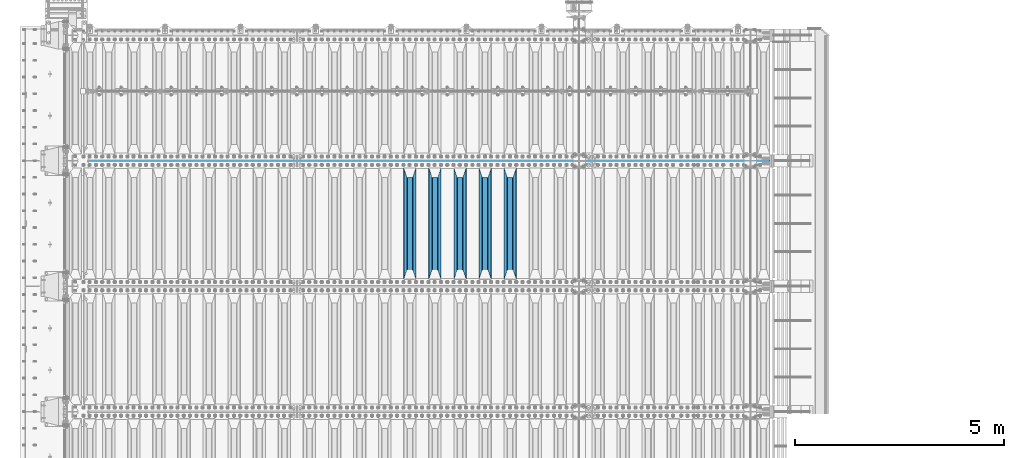
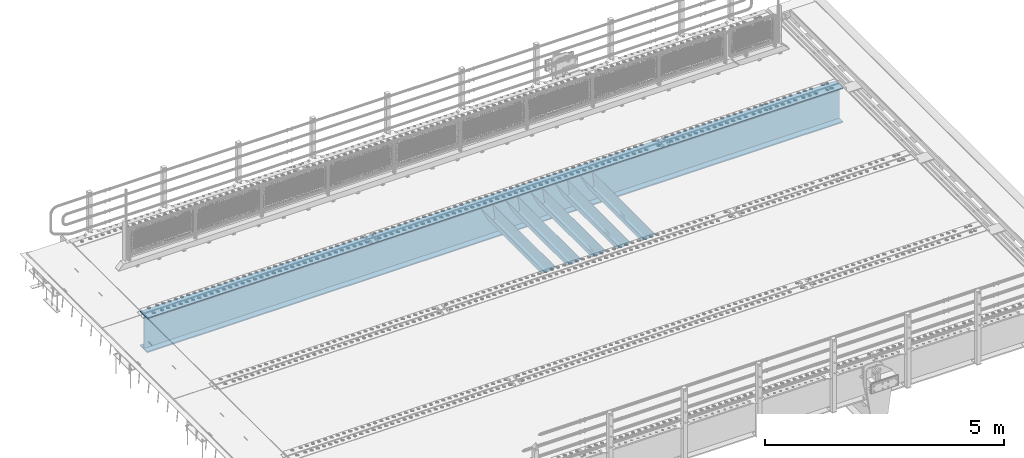
# One storey, part 121 of 257: 6 beams.
"""IFC2X3 building model written with IfcOpenShell, lengths in millimetres."""

from ifc_helpers import new_model, si_unit, frame, origin_with_axes, place, context, subcontext, project, spatial, faceted_brep, material, type_object, element, save


model = new_model("IFC2X3")

# Units and contexts
model_context = context("Model", 3, precision=1e-05, world=origin_with_axes())
body_context = subcontext(model_context, "Body", "Model", "MODEL_VIEW")
ifc_project = project(units=[si_unit("LENGTHUNIT", "METRE", prefix="MILLI"), si_unit("AREAUNIT", "SQUARE_METRE"), si_unit("VOLUMEUNIT", "CUBIC_METRE"), si_unit("MASSUNIT", "GRAM", prefix="KILO"), si_unit("TIMEUNIT", "SECOND"), si_unit("PLANEANGLEUNIT", "RADIAN"), si_unit("SOLIDANGLEUNIT", "STERADIAN"), si_unit("THERMODYNAMICTEMPERATUREUNIT", "DEGREE_CELSIUS"), si_unit("LUMINOUSINTENSITYUNIT", "LUMEN")], contexts=[model_context])

# Site, building, storey
site_placement = place(None, origin_with_axes())
site = spatial("IfcSite", under=ifc_project, at=site_placement, CompositionType="ELEMENT")
building_placement = place(site_placement, origin_with_axes())
building = spatial("IfcBuilding", under=site, at=building_placement, Name="Standard", CompositionType="ELEMENT")
storey_placement = place(building_placement, origin_with_axes())
storey = spatial("IfcBuildingStorey", under=building, at=storey_placement, Name="Undefined", CompositionType="ELEMENT", Elevation=0.0)

# Beams
ifc_material = material(Name="STEEL/S355N")
beam_type_1 = type_object("IfcBeamType", PredefinedType="NOTDEFINED")
beam_1_placement = place(storey_placement, frame((53050.0, 6175.0, -115.0), z_axis=(0.0, 0.0, 1.0), x_axis=(0.0, 1.0, 0.0)))
element("IfcBeam", 1, at=beam_1_placement, inside=storey, type_object=beam_type_1, material=ifc_material, context=body_context, shape_type="Brep", body=[
    faceted_brep([(0.0, 150.0, 115.0), (0.0, 143.690000000002, 115.0), (2650.00000000297, 143.690000000002, 115.0), (2650.00000000297, 150.0, 115.0), (2650.00000000297, 142.059565218406, 110.0000000031), (2650.00000000297, 148.369565218403, 110.0000000031), (2441.90079219208, -80.1103600731149, -98.0992078077845), (2437.7588105432, -77.5672621345584, -102.241189456673), (2434.06523489746, -74.4080125315522, -105.934765102404), (2430.91086095089, -70.7102721255724, -109.089139048974), (2428.37322971128, -66.5649389910031, -111.626770288588), (2426.51472138055, -62.0739139532889, -113.485278619323), (2425.38102192091, -57.3475956567636, -114.618978078955), (2424.99999999987, -52.5021667386536, -115.0), (2424.99999999987, 52.5021667386536, -115.0), (2425.38102192091, 57.3475956567636, -114.618978078955), (2426.51472138055, 62.0739139532889, -113.485278619323), (2428.37322971128, 66.5649389910031, -111.626770288588), (2430.91086095089, 70.7102721255724, -109.089139048974), (2434.06523489746, 74.4080125315522, -105.934765102404), (2437.7588105432, 77.5672621345584, -102.241189456673), (2441.90079219208, 80.1103600731149, -98.0992078077846), (2446.38936140511, 81.9747917625791, -93.6106385947584), (2448.24948500409, 76.2713538057287, -91.7505149957729), (2444.62967112262, 74.76777986261, -95.3703288772456), (2441.28936334126, 72.7168944282894, -98.710636658607), (2438.31067330438, 70.1691124903809, -101.689326695487), (2435.76682334747, 67.1870637758839, -104.233176652398), (2433.72034654133, 63.8440531834931, -106.279653458539), (2432.22154950041, 60.2222587982324, -107.778450499454), (2431.30727574265, 56.4107117849126, -108.692724257221), (2430.99999999987, 52.5031078186876, -109.0), (2430.99999999987, -52.5031078186876, -109.0), (2431.30727574265, -56.4107117849126, -108.692724257221), (2432.22154950041, -60.2222587982324, -107.778450499454), (2433.72034654133, -63.8440531834931, -106.279653458539), (2435.76682334747, -67.1870637758839, -104.233176652398), (2438.31067330438, -70.1691124903809, -101.689326695487), (2441.28936334126, -72.7168944282894, -98.7106366586071), (2444.62967112262, -74.76777986261, -95.3703288772457), (2448.24948500409, -76.2713538057287, -91.7505149957729), (2650.00000000297, -142.059565218406, 110.0000000031), (2650.00000000297, -148.369565218403, 110.0000000031), (2446.38936140511, -81.9747917625791, -93.6106385947584), (2650.00000000297, -143.690000000002, 115.0), (2650.00000000297, -150.0, 115.0), (0.0, -143.690000000002, 115.0), (0.0, -150.0, 115.0), (0.0, -148.369565218258, 110.000000002662), (203.61063859742, -81.9747917625791, -93.6106385947584), (208.099207810447, -80.1103600731149, -98.0992078077845), (212.241189459335, -77.5672621345584, -102.241189456673), (215.934765105066, -74.4080125315522, -105.934765102404), (219.089139051636, -70.7102721255724, -109.089139048974), (221.626770291251, -66.5649389910031, -111.626770288588), (223.485278621985, -62.0739139532889, -113.485278619323), (224.618978081617, -57.3475956567636, -114.618978078955), (225.000000002662, -52.5021667386536, -115.0), (225.000000002662, 52.5021667386536, -115.0), (224.618978081617, 57.3475956567636, -114.618978078955), (223.485278621985, 62.0739139532889, -113.485278619323), (221.626770291251, 66.5649389910031, -111.626770288588), (219.089139051636, 70.7102721255724, -109.089139048974), (215.934765105066, 74.4080125315522, -105.934765102404), (212.241189459335, 77.5672621345584, -102.241189456673), (208.099207810447, 80.1103600731149, -98.0992078077846), (203.61063859742, 81.9747917625791, -93.6106385947584), (0.0, 148.369565218258, 110.000000002662), (0.0, 142.05956521826, 110.000000002662), (201.750514998435, 76.2713538057287, -91.7505149957729), (205.370328879908, 74.76777986261, -95.3703288772456), (208.710636661269, 72.7168944282894, -98.710636658607), (211.689326698149, 70.1691124903809, -101.689326695487), (214.233176655061, 67.1870637758839, -104.233176652398), (216.279653461201, 63.8440531834931, -106.279653458539), (217.778450502116, 60.2222587982324, -107.778450499454), (218.692724259884, 56.4107117849126, -108.692724257221), (219.000000002662, 52.5031078186876, -109.0), (219.000000002662, -52.5031078186876, -109.0), (218.692724259884, -56.4107117849126, -108.692724257221), (217.778450502116, -60.2222587982324, -107.778450499454), (216.279653461201, -63.8440531834931, -106.279653458539), (214.233176655061, -67.1870637758839, -104.233176652398), (211.689326698149, -70.1691124903809, -101.689326695487), (208.710636661269, -72.7168944282894, -98.7106366586071), (205.370328879908, -74.76777986261, -95.3703288772457), (201.750514998435, -76.2713538057287, -91.7505149957729), (0.0, -142.05956521826, 110.000000002662)], [[[0, 1, 2, 3]], [[3, 2, 4, 5]], [[6, 7, 8, 9, 10, 11, 12, 13, 14, 15, 16, 17, 18, 19, 20, 21, 22, 5, 4, 23, 24, 25, 26, 27, 28, 29, 30, 31, 32, 33, 34, 35, 36, 37, 38, 39, 40, 41, 42, 43]], [[44, 45, 42, 41]], [[46, 47, 45, 44]], [[43, 42, 45, 47, 48, 49]], [[6, 43, 49, 50]], [[7, 6, 50, 51]], [[8, 7, 51, 52]], [[9, 8, 52, 53]], [[10, 9, 53, 54]], [[11, 10, 54, 55]], [[12, 11, 55, 56]], [[13, 12, 56, 57]], [[14, 13, 57, 58]], [[15, 14, 58, 59]], [[16, 15, 59, 60]], [[17, 16, 60, 61]], [[18, 17, 61, 62]], [[19, 18, 62, 63]], [[20, 19, 63, 64]], [[21, 20, 64, 65]], [[22, 21, 65, 66]], [[0, 3, 5, 22, 66, 67]], [[1, 0, 67, 68]], [[23, 4, 2, 1, 68, 69]], [[24, 23, 69, 70]], [[25, 24, 70, 71]], [[26, 25, 71, 72]], [[27, 26, 72, 73]], [[28, 27, 73, 74]], [[29, 28, 74, 75]], [[30, 29, 75, 76]], [[31, 30, 76, 77]], [[32, 31, 77, 78]], [[33, 32, 78, 79]], [[34, 33, 79, 80]], [[35, 34, 80, 81]], [[36, 35, 81, 82]], [[37, 36, 82, 83]], [[38, 37, 83, 84]], [[39, 38, 84, 85]], [[40, 39, 85, 86]], [[46, 44, 41, 40, 86, 87]], [[47, 46, 87, 48]], [[86, 85, 84, 83, 82, 81, 80, 79, 78, 77, 76, 75, 74, 73, 72, 71, 70, 69, 68, 67, 66, 65, 64, 63, 62, 61, 60, 59, 58, 57, 56, 55, 54, 53, 52, 51, 50, 49, 48, 87]]]),
])
beam_2_placement = place(storey_placement, frame((52450.0, 6175.0, -115.0), z_axis=(0.0, 0.0, 1.0), x_axis=(0.0, 1.0, 0.0)))
element("IfcBeam", 2, at=beam_2_placement, inside=storey, type_object=beam_type_1, material=ifc_material, context=body_context, shape_type="Brep", body=[
    faceted_brep([(0.0, 150.0, 115.0), (0.0, 143.690000000002, 115.0), (2650.00000000297, 143.690000000002, 115.0), (2650.00000000297, 150.0, 115.0), (2650.00000000297, 142.059565218406, 110.0000000031), (2650.00000000297, 148.369565218403, 110.0000000031), (2441.90079219208, -80.1103600731149, -98.0992078077845), (2437.7588105432, -77.5672621345584, -102.241189456673), (2434.06523489746, -74.4080125315522, -105.934765102404), (2430.91086095089, -70.7102721255724, -109.089139048974), (2428.37322971128, -66.5649389910031, -111.626770288588), (2426.51472138055, -62.0739139532889, -113.485278619323), (2425.38102192091, -57.3475956567636, -114.618978078955), (2424.99999999987, -52.5021667386536, -115.0), (2424.99999999987, 52.5021667386536, -115.0), (2425.38102192091, 57.3475956567636, -114.618978078955), (2426.51472138055, 62.0739139532889, -113.485278619323), (2428.37322971128, 66.5649389910031, -111.626770288588), (2430.91086095089, 70.7102721255724, -109.089139048974), (2434.06523489746, 74.4080125315522, -105.934765102404), (2437.7588105432, 77.5672621345584, -102.241189456673), (2441.90079219208, 80.1103600731149, -98.0992078077846), (2446.38936140511, 81.9747917625791, -93.6106385947584), (2448.24948500409, 76.2713538057287, -91.7505149957729), (2444.62967112262, 74.76777986261, -95.3703288772456), (2441.28936334126, 72.7168944282894, -98.710636658607), (2438.31067330438, 70.1691124903809, -101.689326695487), (2435.76682334747, 67.1870637758839, -104.233176652398), (2433.72034654133, 63.8440531834931, -106.279653458539), (2432.22154950041, 60.2222587982324, -107.778450499454), (2431.30727574265, 56.4107117849126, -108.692724257221), (2430.99999999987, 52.5031078186876, -109.0), (2430.99999999987, -52.5031078186876, -109.0), (2431.30727574265, -56.4107117849126, -108.692724257221), (2432.22154950041, -60.2222587982324, -107.778450499454), (2433.72034654133, -63.8440531834931, -106.279653458539), (2435.76682334747, -67.1870637758839, -104.233176652398), (2438.31067330438, -70.1691124903809, -101.689326695487), (2441.28936334126, -72.7168944282894, -98.7106366586071), (2444.62967112262, -74.76777986261, -95.3703288772457), (2448.24948500409, -76.2713538057287, -91.7505149957729), (2650.00000000297, -142.059565218406, 110.0000000031), (2650.00000000297, -148.369565218403, 110.0000000031), (2446.38936140511, -81.9747917625791, -93.6106385947584), (2650.00000000297, -143.690000000002, 115.0), (2650.00000000297, -150.0, 115.0), (0.0, -143.690000000002, 115.0), (0.0, -150.0, 115.0), (0.0, -148.369565218258, 110.000000002662), (203.61063859742, -81.9747917625791, -93.6106385947584), (208.099207810447, -80.1103600731149, -98.0992078077845), (212.241189459335, -77.5672621345584, -102.241189456673), (215.934765105066, -74.4080125315522, -105.934765102404), (219.089139051636, -70.7102721255724, -109.089139048974), (221.626770291251, -66.5649389910031, -111.626770288588), (223.485278621985, -62.0739139532889, -113.485278619323), (224.618978081617, -57.3475956567636, -114.618978078955), (225.000000002662, -52.5021667386536, -115.0), (225.000000002662, 52.5021667386536, -115.0), (224.618978081617, 57.3475956567636, -114.618978078955), (223.485278621985, 62.0739139532889, -113.485278619323), (221.626770291251, 66.5649389910031, -111.626770288588), (219.089139051636, 70.7102721255724, -109.089139048974), (215.934765105066, 74.4080125315522, -105.934765102404), (212.241189459335, 77.5672621345584, -102.241189456673), (208.099207810447, 80.1103600731149, -98.0992078077846), (203.61063859742, 81.9747917625791, -93.6106385947584), (0.0, 148.369565218258, 110.000000002662), (0.0, 142.05956521826, 110.000000002662), (201.750514998435, 76.2713538057287, -91.7505149957729), (205.370328879908, 74.76777986261, -95.3703288772456), (208.710636661269, 72.7168944282894, -98.710636658607), (211.689326698149, 70.1691124903809, -101.689326695487), (214.233176655061, 67.1870637758839, -104.233176652398), (216.279653461201, 63.8440531834931, -106.279653458539), (217.778450502116, 60.2222587982324, -107.778450499454), (218.692724259884, 56.4107117849126, -108.692724257221), (219.000000002662, 52.5031078186876, -109.0), (219.000000002662, -52.5031078186876, -109.0), (218.692724259884, -56.4107117849126, -108.692724257221), (217.778450502116, -60.2222587982324, -107.778450499454), (216.279653461201, -63.8440531834931, -106.279653458539), (214.233176655061, -67.1870637758839, -104.233176652398), (211.689326698149, -70.1691124903809, -101.689326695487), (208.710636661269, -72.7168944282894, -98.7106366586071), (205.370328879908, -74.76777986261, -95.3703288772457), (201.750514998435, -76.2713538057287, -91.7505149957729), (0.0, -142.05956521826, 110.000000002662)], [[[0, 1, 2, 3]], [[3, 2, 4, 5]], [[6, 7, 8, 9, 10, 11, 12, 13, 14, 15, 16, 17, 18, 19, 20, 21, 22, 5, 4, 23, 24, 25, 26, 27, 28, 29, 30, 31, 32, 33, 34, 35, 36, 37, 38, 39, 40, 41, 42, 43]], [[44, 45, 42, 41]], [[46, 47, 45, 44]], [[43, 42, 45, 47, 48, 49]], [[6, 43, 49, 50]], [[7, 6, 50, 51]], [[8, 7, 51, 52]], [[9, 8, 52, 53]], [[10, 9, 53, 54]], [[11, 10, 54, 55]], [[12, 11, 55, 56]], [[13, 12, 56, 57]], [[14, 13, 57, 58]], [[15, 14, 58, 59]], [[16, 15, 59, 60]], [[17, 16, 60, 61]], [[18, 17, 61, 62]], [[19, 18, 62, 63]], [[20, 19, 63, 64]], [[21, 20, 64, 65]], [[22, 21, 65, 66]], [[0, 3, 5, 22, 66, 67]], [[1, 0, 67, 68]], [[23, 4, 2, 1, 68, 69]], [[24, 23, 69, 70]], [[25, 24, 70, 71]], [[26, 25, 71, 72]], [[27, 26, 72, 73]], [[28, 27, 73, 74]], [[29, 28, 74, 75]], [[30, 29, 75, 76]], [[31, 30, 76, 77]], [[32, 31, 77, 78]], [[33, 32, 78, 79]], [[34, 33, 79, 80]], [[35, 34, 80, 81]], [[36, 35, 81, 82]], [[37, 36, 82, 83]], [[38, 37, 83, 84]], [[39, 38, 84, 85]], [[40, 39, 85, 86]], [[46, 44, 41, 40, 86, 87]], [[47, 46, 87, 48]], [[86, 85, 84, 83, 82, 81, 80, 79, 78, 77, 76, 75, 74, 73, 72, 71, 70, 69, 68, 67, 66, 65, 64, 63, 62, 61, 60, 59, 58, 57, 56, 55, 54, 53, 52, 51, 50, 49, 48, 87]]]),
])
beam_3_placement = place(storey_placement, frame((51850.0, 6175.0, -115.0), z_axis=(0.0, 0.0, 1.0), x_axis=(0.0, 1.0, 0.0)))
element("IfcBeam", 3, at=beam_3_placement, inside=storey, type_object=beam_type_1, material=ifc_material, context=body_context, shape_type="Brep", body=[
    faceted_brep([(0.0, 150.0, 115.0), (0.0, 143.690000000002, 115.0), (2650.00000000297, 143.690000000002, 115.0), (2650.00000000297, 150.0, 115.0), (2650.00000000297, 142.059565218406, 110.0000000031), (2650.00000000297, 148.369565218403, 110.0000000031), (2441.90079219208, -80.1103600731149, -98.0992078077845), (2437.7588105432, -77.5672621345584, -102.241189456673), (2434.06523489746, -74.4080125315522, -105.934765102404), (2430.91086095089, -70.7102721255724, -109.089139048974), (2428.37322971128, -66.5649389910031, -111.626770288588), (2426.51472138055, -62.0739139532889, -113.485278619323), (2425.38102192091, -57.3475956567636, -114.618978078955), (2424.99999999987, -52.5021667386536, -115.0), (2424.99999999987, 52.5021667386536, -115.0), (2425.38102192091, 57.3475956567636, -114.618978078955), (2426.51472138055, 62.0739139532889, -113.485278619323), (2428.37322971128, 66.5649389910031, -111.626770288588), (2430.91086095089, 70.7102721255724, -109.089139048974), (2434.06523489746, 74.4080125315522, -105.934765102404), (2437.7588105432, 77.5672621345584, -102.241189456673), (2441.90079219208, 80.1103600731149, -98.0992078077846), (2446.38936140511, 81.9747917625791, -93.6106385947584), (2448.24948500409, 76.2713538057287, -91.7505149957729), (2444.62967112262, 74.76777986261, -95.3703288772456), (2441.28936334126, 72.7168944282894, -98.710636658607), (2438.31067330438, 70.1691124903809, -101.689326695487), (2435.76682334747, 67.1870637758839, -104.233176652398), (2433.72034654133, 63.8440531834931, -106.279653458539), (2432.22154950041, 60.2222587982324, -107.778450499454), (2431.30727574265, 56.4107117849126, -108.692724257221), (2430.99999999987, 52.5031078186876, -109.0), (2430.99999999987, -52.5031078186876, -109.0), (2431.30727574265, -56.4107117849126, -108.692724257221), (2432.22154950041, -60.2222587982324, -107.778450499454), (2433.72034654133, -63.8440531834931, -106.279653458539), (2435.76682334747, -67.1870637758839, -104.233176652398), (2438.31067330438, -70.1691124903809, -101.689326695487), (2441.28936334126, -72.7168944282894, -98.7106366586071), (2444.62967112262, -74.76777986261, -95.3703288772457), (2448.24948500409, -76.2713538057287, -91.7505149957729), (2650.00000000297, -142.059565218406, 110.0000000031), (2650.00000000297, -148.369565218403, 110.0000000031), (2446.38936140511, -81.9747917625791, -93.6106385947584), (2650.00000000297, -143.690000000002, 115.0), (2650.00000000297, -150.0, 115.0), (0.0, -143.690000000002, 115.0), (0.0, -150.0, 115.0), (0.0, -148.369565218258, 110.000000002662), (203.61063859742, -81.9747917625791, -93.6106385947584), (208.099207810447, -80.1103600731149, -98.0992078077845), (212.241189459335, -77.5672621345584, -102.241189456673), (215.934765105066, -74.4080125315522, -105.934765102404), (219.089139051636, -70.7102721255724, -109.089139048974), (221.626770291251, -66.5649389910031, -111.626770288588), (223.485278621985, -62.0739139532889, -113.485278619323), (224.618978081617, -57.3475956567636, -114.618978078955), (225.000000002662, -52.5021667386536, -115.0), (225.000000002662, 52.5021667386536, -115.0), (224.618978081617, 57.3475956567636, -114.618978078955), (223.485278621985, 62.0739139532889, -113.485278619323), (221.626770291251, 66.5649389910031, -111.626770288588), (219.089139051636, 70.7102721255724, -109.089139048974), (215.934765105066, 74.4080125315522, -105.934765102404), (212.241189459335, 77.5672621345584, -102.241189456673), (208.099207810447, 80.1103600731149, -98.0992078077846), (203.61063859742, 81.9747917625791, -93.6106385947584), (0.0, 148.369565218258, 110.000000002662), (0.0, 142.05956521826, 110.000000002662), (201.750514998435, 76.2713538057287, -91.7505149957729), (205.370328879908, 74.76777986261, -95.3703288772456), (208.710636661269, 72.7168944282894, -98.710636658607), (211.689326698149, 70.1691124903809, -101.689326695487), (214.233176655061, 67.1870637758839, -104.233176652398), (216.279653461201, 63.8440531834931, -106.279653458539), (217.778450502116, 60.2222587982324, -107.778450499454), (218.692724259884, 56.4107117849126, -108.692724257221), (219.000000002662, 52.5031078186876, -109.0), (219.000000002662, -52.5031078186876, -109.0), (218.692724259884, -56.4107117849126, -108.692724257221), (217.778450502116, -60.2222587982324, -107.778450499454), (216.279653461201, -63.8440531834931, -106.279653458539), (214.233176655061, -67.1870637758839, -104.233176652398), (211.689326698149, -70.1691124903809, -101.689326695487), (208.710636661269, -72.7168944282894, -98.7106366586071), (205.370328879908, -74.76777986261, -95.3703288772457), (201.750514998435, -76.2713538057287, -91.7505149957729), (0.0, -142.05956521826, 110.000000002662)], [[[0, 1, 2, 3]], [[3, 2, 4, 5]], [[6, 7, 8, 9, 10, 11, 12, 13, 14, 15, 16, 17, 18, 19, 20, 21, 22, 5, 4, 23, 24, 25, 26, 27, 28, 29, 30, 31, 32, 33, 34, 35, 36, 37, 38, 39, 40, 41, 42, 43]], [[44, 45, 42, 41]], [[46, 47, 45, 44]], [[43, 42, 45, 47, 48, 49]], [[6, 43, 49, 50]], [[7, 6, 50, 51]], [[8, 7, 51, 52]], [[9, 8, 52, 53]], [[10, 9, 53, 54]], [[11, 10, 54, 55]], [[12, 11, 55, 56]], [[13, 12, 56, 57]], [[14, 13, 57, 58]], [[15, 14, 58, 59]], [[16, 15, 59, 60]], [[17, 16, 60, 61]], [[18, 17, 61, 62]], [[19, 18, 62, 63]], [[20, 19, 63, 64]], [[21, 20, 64, 65]], [[22, 21, 65, 66]], [[0, 3, 5, 22, 66, 67]], [[1, 0, 67, 68]], [[23, 4, 2, 1, 68, 69]], [[24, 23, 69, 70]], [[25, 24, 70, 71]], [[26, 25, 71, 72]], [[27, 26, 72, 73]], [[28, 27, 73, 74]], [[29, 28, 74, 75]], [[30, 29, 75, 76]], [[31, 30, 76, 77]], [[32, 31, 77, 78]], [[33, 32, 78, 79]], [[34, 33, 79, 80]], [[35, 34, 80, 81]], [[36, 35, 81, 82]], [[37, 36, 82, 83]], [[38, 37, 83, 84]], [[39, 38, 84, 85]], [[40, 39, 85, 86]], [[46, 44, 41, 40, 86, 87]], [[47, 46, 87, 48]], [[86, 85, 84, 83, 82, 81, 80, 79, 78, 77, 76, 75, 74, 73, 72, 71, 70, 69, 68, 67, 66, 65, 64, 63, 62, 61, 60, 59, 58, 57, 56, 55, 54, 53, 52, 51, 50, 49, 48, 87]]]),
])
beam_4_placement = place(storey_placement, frame((51250.0, 6175.0, -115.0), z_axis=(0.0, 0.0, 1.0), x_axis=(0.0, 1.0, 0.0)))
element("IfcBeam", 4, at=beam_4_placement, inside=storey, type_object=beam_type_1, material=ifc_material, context=body_context, shape_type="Brep", body=[
    faceted_brep([(0.0, 150.0, 115.0), (0.0, 143.690000000002, 115.0), (2650.00000000297, 143.690000000002, 115.0), (2650.00000000297, 150.0, 115.0), (2650.00000000297, 142.059565218406, 110.0000000031), (2650.00000000297, 148.369565218403, 110.0000000031), (2441.90079219208, -80.1103600731149, -98.0992078077845), (2437.7588105432, -77.5672621345584, -102.241189456673), (2434.06523489746, -74.4080125315522, -105.934765102404), (2430.91086095089, -70.7102721255724, -109.089139048974), (2428.37322971128, -66.5649389910031, -111.626770288588), (2426.51472138055, -62.0739139532889, -113.485278619323), (2425.38102192091, -57.3475956567636, -114.618978078955), (2424.99999999987, -52.5021667386536, -115.0), (2424.99999999987, 52.5021667386536, -115.0), (2425.38102192091, 57.3475956567636, -114.618978078955), (2426.51472138055, 62.0739139532889, -113.485278619323), (2428.37322971128, 66.5649389910031, -111.626770288588), (2430.91086095089, 70.7102721255724, -109.089139048974), (2434.06523489746, 74.4080125315522, -105.934765102404), (2437.7588105432, 77.5672621345584, -102.241189456673), (2441.90079219208, 80.1103600731149, -98.0992078077846), (2446.38936140511, 81.9747917625791, -93.6106385947584), (2448.24948500409, 76.2713538057287, -91.7505149957729), (2444.62967112262, 74.76777986261, -95.3703288772456), (2441.28936334126, 72.7168944282894, -98.710636658607), (2438.31067330438, 70.1691124903809, -101.689326695487), (2435.76682334747, 67.1870637758839, -104.233176652398), (2433.72034654133, 63.8440531834931, -106.279653458539), (2432.22154950041, 60.2222587982324, -107.778450499454), (2431.30727574265, 56.4107117849126, -108.692724257221), (2430.99999999987, 52.5031078186876, -109.0), (2430.99999999987, -52.5031078186876, -109.0), (2431.30727574265, -56.4107117849126, -108.692724257221), (2432.22154950041, -60.2222587982324, -107.778450499454), (2433.72034654133, -63.8440531834931, -106.279653458539), (2435.76682334747, -67.1870637758839, -104.233176652398), (2438.31067330438, -70.1691124903809, -101.689326695487), (2441.28936334126, -72.7168944282894, -98.7106366586071), (2444.62967112262, -74.76777986261, -95.3703288772457), (2448.24948500409, -76.2713538057287, -91.7505149957729), (2650.00000000297, -142.059565218406, 110.0000000031), (2650.00000000297, -148.369565218403, 110.0000000031), (2446.38936140511, -81.9747917625791, -93.6106385947584), (2650.00000000297, -143.690000000002, 115.0), (2650.00000000297, -150.0, 115.0), (0.0, -143.690000000002, 115.0), (0.0, -150.0, 115.0), (0.0, -148.369565218258, 110.000000002662), (203.61063859742, -81.9747917625791, -93.6106385947584), (208.099207810447, -80.1103600731149, -98.0992078077845), (212.241189459335, -77.5672621345584, -102.241189456673), (215.934765105066, -74.4080125315522, -105.934765102404), (219.089139051636, -70.7102721255724, -109.089139048974), (221.626770291251, -66.5649389910031, -111.626770288588), (223.485278621985, -62.0739139532889, -113.485278619323), (224.618978081617, -57.3475956567636, -114.618978078955), (225.000000002662, -52.5021667386536, -115.0), (225.000000002662, 52.5021667386536, -115.0), (224.618978081617, 57.3475956567636, -114.618978078955), (223.485278621985, 62.0739139532889, -113.485278619323), (221.626770291251, 66.5649389910031, -111.626770288588), (219.089139051636, 70.7102721255724, -109.089139048974), (215.934765105066, 74.4080125315522, -105.934765102404), (212.241189459335, 77.5672621345584, -102.241189456673), (208.099207810447, 80.1103600731149, -98.0992078077846), (203.61063859742, 81.9747917625791, -93.6106385947584), (0.0, 148.369565218258, 110.000000002662), (0.0, 142.05956521826, 110.000000002662), (201.750514998435, 76.2713538057287, -91.7505149957729), (205.370328879908, 74.76777986261, -95.3703288772456), (208.710636661269, 72.7168944282894, -98.710636658607), (211.689326698149, 70.1691124903809, -101.689326695487), (214.233176655061, 67.1870637758839, -104.233176652398), (216.279653461201, 63.8440531834931, -106.279653458539), (217.778450502116, 60.2222587982324, -107.778450499454), (218.692724259884, 56.4107117849126, -108.692724257221), (219.000000002662, 52.5031078186876, -109.0), (219.000000002662, -52.5031078186876, -109.0), (218.692724259884, -56.4107117849126, -108.692724257221), (217.778450502116, -60.2222587982324, -107.778450499454), (216.279653461201, -63.8440531834931, -106.279653458539), (214.233176655061, -67.1870637758839, -104.233176652398), (211.689326698149, -70.1691124903809, -101.689326695487), (208.710636661269, -72.7168944282894, -98.7106366586071), (205.370328879908, -74.76777986261, -95.3703288772457), (201.750514998435, -76.2713538057287, -91.7505149957729), (0.0, -142.05956521826, 110.000000002662)], [[[0, 1, 2, 3]], [[3, 2, 4, 5]], [[6, 7, 8, 9, 10, 11, 12, 13, 14, 15, 16, 17, 18, 19, 20, 21, 22, 5, 4, 23, 24, 25, 26, 27, 28, 29, 30, 31, 32, 33, 34, 35, 36, 37, 38, 39, 40, 41, 42, 43]], [[44, 45, 42, 41]], [[46, 47, 45, 44]], [[43, 42, 45, 47, 48, 49]], [[6, 43, 49, 50]], [[7, 6, 50, 51]], [[8, 7, 51, 52]], [[9, 8, 52, 53]], [[10, 9, 53, 54]], [[11, 10, 54, 55]], [[12, 11, 55, 56]], [[13, 12, 56, 57]], [[14, 13, 57, 58]], [[15, 14, 58, 59]], [[16, 15, 59, 60]], [[17, 16, 60, 61]], [[18, 17, 61, 62]], [[19, 18, 62, 63]], [[20, 19, 63, 64]], [[21, 20, 64, 65]], [[22, 21, 65, 66]], [[0, 3, 5, 22, 66, 67]], [[1, 0, 67, 68]], [[23, 4, 2, 1, 68, 69]], [[24, 23, 69, 70]], [[25, 24, 70, 71]], [[26, 25, 71, 72]], [[27, 26, 72, 73]], [[28, 27, 73, 74]], [[29, 28, 74, 75]], [[30, 29, 75, 76]], [[31, 30, 76, 77]], [[32, 31, 77, 78]], [[33, 32, 78, 79]], [[34, 33, 79, 80]], [[35, 34, 80, 81]], [[36, 35, 81, 82]], [[37, 36, 82, 83]], [[38, 37, 83, 84]], [[39, 38, 84, 85]], [[40, 39, 85, 86]], [[46, 44, 41, 40, 86, 87]], [[47, 46, 87, 48]], [[86, 85, 84, 83, 82, 81, 80, 79, 78, 77, 76, 75, 74, 73, 72, 71, 70, 69, 68, 67, 66, 65, 64, 63, 62, 61, 60, 59, 58, 57, 56, 55, 54, 53, 52, 51, 50, 49, 48, 87]]]),
])
beam_5_placement = place(storey_placement, frame((50650.0, 6175.0, -115.0), z_axis=(0.0, 0.0, 1.0), x_axis=(0.0, 1.0, 0.0)))
element("IfcBeam", 5, at=beam_5_placement, inside=storey, type_object=beam_type_1, material=ifc_material, context=body_context, shape_type="Brep", body=[
    faceted_brep([(0.0, 150.0, 115.0), (0.0, 143.690000000002, 115.0), (2650.00000000297, 143.690000000002, 115.0), (2650.00000000297, 150.0, 115.0), (2650.00000000297, 142.059565218406, 110.0000000031), (2650.00000000297, 148.369565218403, 110.0000000031), (2441.90079219208, -80.1103600731149, -98.0992078077845), (2437.7588105432, -77.5672621345584, -102.241189456673), (2434.06523489746, -74.4080125315522, -105.934765102404), (2430.91086095089, -70.7102721255724, -109.089139048974), (2428.37322971128, -66.5649389910031, -111.626770288588), (2426.51472138055, -62.0739139532889, -113.485278619323), (2425.38102192091, -57.3475956567636, -114.618978078955), (2424.99999999987, -52.5021667386536, -115.0), (2424.99999999987, 52.5021667386536, -115.0), (2425.38102192091, 57.3475956567636, -114.618978078955), (2426.51472138055, 62.0739139532889, -113.485278619323), (2428.37322971128, 66.5649389910031, -111.626770288588), (2430.91086095089, 70.7102721255724, -109.089139048974), (2434.06523489746, 74.4080125315522, -105.934765102404), (2437.7588105432, 77.5672621345584, -102.241189456673), (2441.90079219208, 80.1103600731149, -98.0992078077846), (2446.38936140511, 81.9747917625791, -93.6106385947584), (2448.24948500409, 76.2713538057287, -91.7505149957729), (2444.62967112262, 74.76777986261, -95.3703288772456), (2441.28936334126, 72.7168944282894, -98.710636658607), (2438.31067330438, 70.1691124903809, -101.689326695487), (2435.76682334747, 67.1870637758839, -104.233176652398), (2433.72034654133, 63.8440531834931, -106.279653458539), (2432.22154950041, 60.2222587982324, -107.778450499454), (2431.30727574265, 56.4107117849126, -108.692724257221), (2430.99999999987, 52.5031078186876, -109.0), (2430.99999999987, -52.5031078186876, -109.0), (2431.30727574265, -56.4107117849126, -108.692724257221), (2432.22154950041, -60.2222587982324, -107.778450499454), (2433.72034654133, -63.8440531834931, -106.279653458539), (2435.76682334747, -67.1870637758839, -104.233176652398), (2438.31067330438, -70.1691124903809, -101.689326695487), (2441.28936334126, -72.7168944282894, -98.7106366586071), (2444.62967112262, -74.76777986261, -95.3703288772457), (2448.24948500409, -76.2713538057287, -91.7505149957729), (2650.00000000297, -142.059565218406, 110.0000000031), (2650.00000000297, -148.369565218403, 110.0000000031), (2446.38936140511, -81.9747917625791, -93.6106385947584), (2650.00000000297, -143.690000000002, 115.0), (2650.00000000297, -150.0, 115.0), (0.0, -143.690000000002, 115.0), (0.0, -150.0, 115.0), (0.0, -148.369565218258, 110.000000002662), (203.61063859742, -81.9747917625791, -93.6106385947584), (208.099207810447, -80.1103600731149, -98.0992078077845), (212.241189459335, -77.5672621345584, -102.241189456673), (215.934765105066, -74.4080125315522, -105.934765102404), (219.089139051636, -70.7102721255724, -109.089139048974), (221.626770291251, -66.5649389910031, -111.626770288588), (223.485278621985, -62.0739139532889, -113.485278619323), (224.618978081617, -57.3475956567636, -114.618978078955), (225.000000002662, -52.5021667386536, -115.0), (225.000000002662, 52.5021667386536, -115.0), (224.618978081617, 57.3475956567636, -114.618978078955), (223.485278621985, 62.0739139532889, -113.485278619323), (221.626770291251, 66.5649389910031, -111.626770288588), (219.089139051636, 70.7102721255724, -109.089139048974), (215.934765105066, 74.4080125315522, -105.934765102404), (212.241189459335, 77.5672621345584, -102.241189456673), (208.099207810447, 80.1103600731149, -98.0992078077846), (203.61063859742, 81.9747917625791, -93.6106385947584), (0.0, 148.369565218258, 110.000000002662), (0.0, 142.05956521826, 110.000000002662), (201.750514998435, 76.2713538057287, -91.7505149957729), (205.370328879908, 74.76777986261, -95.3703288772456), (208.710636661269, 72.7168944282894, -98.710636658607), (211.689326698149, 70.1691124903809, -101.689326695487), (214.233176655061, 67.1870637758839, -104.233176652398), (216.279653461201, 63.8440531834931, -106.279653458539), (217.778450502116, 60.2222587982324, -107.778450499454), (218.692724259884, 56.4107117849126, -108.692724257221), (219.000000002662, 52.5031078186876, -109.0), (219.000000002662, -52.5031078186876, -109.0), (218.692724259884, -56.4107117849126, -108.692724257221), (217.778450502116, -60.2222587982324, -107.778450499454), (216.279653461201, -63.8440531834931, -106.279653458539), (214.233176655061, -67.1870637758839, -104.233176652398), (211.689326698149, -70.1691124903809, -101.689326695487), (208.710636661269, -72.7168944282894, -98.7106366586071), (205.370328879908, -74.76777986261, -95.3703288772457), (201.750514998435, -76.2713538057287, -91.7505149957729), (0.0, -142.05956521826, 110.000000002662)], [[[0, 1, 2, 3]], [[3, 2, 4, 5]], [[6, 7, 8, 9, 10, 11, 12, 13, 14, 15, 16, 17, 18, 19, 20, 21, 22, 5, 4, 23, 24, 25, 26, 27, 28, 29, 30, 31, 32, 33, 34, 35, 36, 37, 38, 39, 40, 41, 42, 43]], [[44, 45, 42, 41]], [[46, 47, 45, 44]], [[43, 42, 45, 47, 48, 49]], [[6, 43, 49, 50]], [[7, 6, 50, 51]], [[8, 7, 51, 52]], [[9, 8, 52, 53]], [[10, 9, 53, 54]], [[11, 10, 54, 55]], [[12, 11, 55, 56]], [[13, 12, 56, 57]], [[14, 13, 57, 58]], [[15, 14, 58, 59]], [[16, 15, 59, 60]], [[17, 16, 60, 61]], [[18, 17, 61, 62]], [[19, 18, 62, 63]], [[20, 19, 63, 64]], [[21, 20, 64, 65]], [[22, 21, 65, 66]], [[0, 3, 5, 22, 66, 67]], [[1, 0, 67, 68]], [[23, 4, 2, 1, 68, 69]], [[24, 23, 69, 70]], [[25, 24, 70, 71]], [[26, 25, 71, 72]], [[27, 26, 72, 73]], [[28, 27, 73, 74]], [[29, 28, 74, 75]], [[30, 29, 75, 76]], [[31, 30, 76, 77]], [[32, 31, 77, 78]], [[33, 32, 78, 79]], [[34, 33, 79, 80]], [[35, 34, 80, 81]], [[36, 35, 81, 82]], [[37, 36, 82, 83]], [[38, 37, 83, 84]], [[39, 38, 84, 85]], [[40, 39, 85, 86]], [[46, 44, 41, 40, 86, 87]], [[47, 46, 87, 48]], [[86, 85, 84, 83, 82, 81, 80, 79, 78, 77, 76, 75, 74, 73, 72, 71, 70, 69, 68, 67, 66, 65, 64, 63, 62, 61, 60, 59, 58, 57, 56, 55, 54, 53, 52, 51, 50, 49, 48, 87]]]),
])
beam_type_2 = type_object("IfcBeamType", Name="HEA900", PredefinedType="NOTDEFINED")
beam_6_placement = place(storey_placement, frame((42460.0, 9000.0, -445.0), z_axis=(0.0, 0.0, 1.0), x_axis=(1.0, 0.0, 0.0)))
element("IfcBeam", 6, at=beam_6_placement, inside=storey, type_object=beam_type_2, material=ifc_material, ObjectType="HEA900", context=body_context, shape_type="Brep", body=[
    faceted_brep([(0.0, 150.0, -445.0), (0.0, 150.0, -415.0), (16807.0, 150.0, -415.0), (16807.0, 150.0, -445.0), (0.0, 8.0, -415.0), (16807.0, 8.0, -415.0), (0.0, 8.0, 415.0), (16807.0, 8.0, 415.0), (0.0, 150.0, 415.0), (16807.0, 150.0, 415.0), (0.0, 150.0, 445.0), (16807.0, 150.0, 445.0), (0.0, -150.0, 445.0), (16807.0, -150.0, 445.0), (0.0, -150.0, 415.0), (16807.0, -150.0, 415.0), (0.0, -8.0, 415.0), (16807.0, -8.0, 415.0), (0.0, -8.0, -415.0), (16807.0, -8.0, -415.0), (0.0, -150.0, -415.0), (16807.0, -150.0, -415.0), (0.0, -150.0, -445.0), (16807.0, -150.0, -445.0)], [[[0, 1, 2, 3]], [[1, 4, 5, 2]], [[4, 6, 7, 5]], [[6, 8, 9, 7]], [[8, 10, 11, 9]], [[10, 12, 13, 11]], [[12, 14, 15, 13]], [[14, 16, 17, 15]], [[16, 18, 19, 17]], [[18, 20, 21, 19]], [[20, 22, 23, 21]], [[22, 0, 3, 23]], [[5, 7, 9, 11, 13, 15, 17, 19, 21, 23, 3, 2]], [[22, 20, 18, 16, 14, 12, 10, 8, 6, 4, 1, 0]]]),
])

save(model, "model.ifc")
